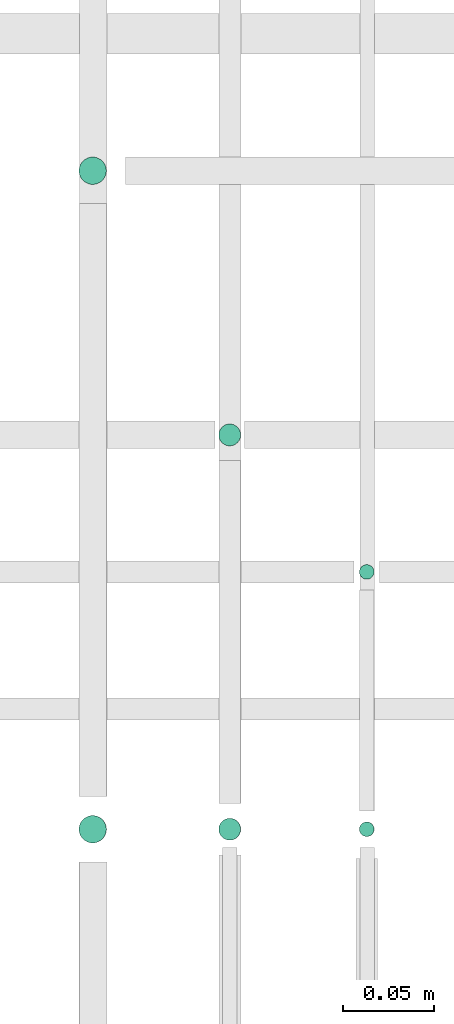
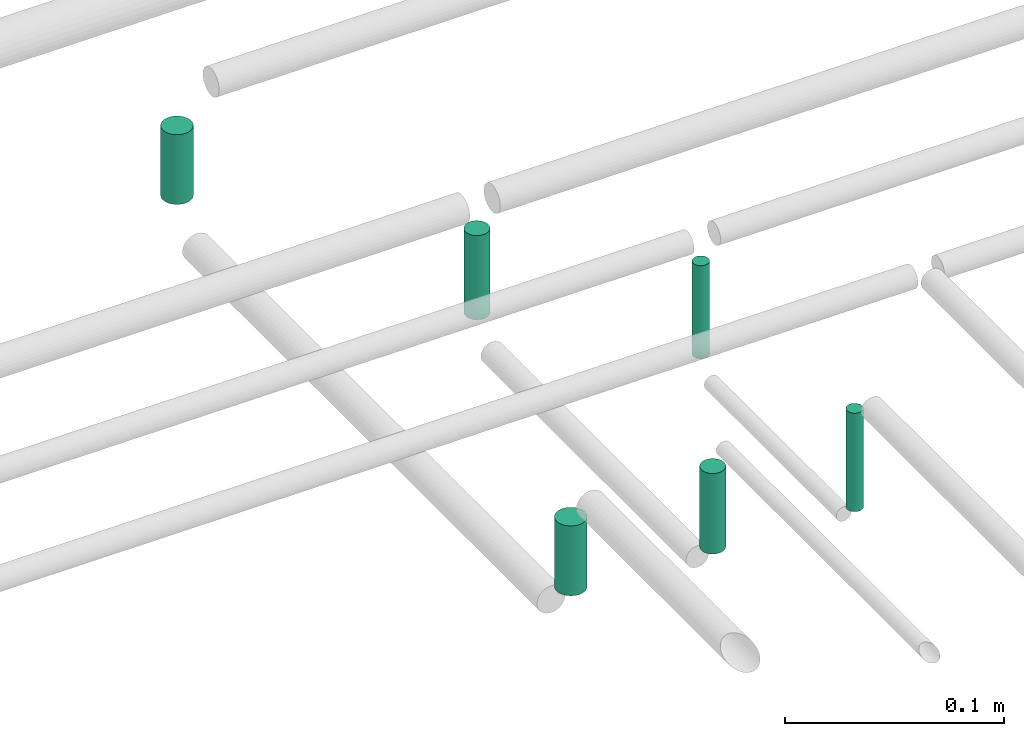
# One storey, part 253 of 331: 6 flow segments.
"""IFC2X3 building model written with IfcOpenShell, lengths in millimetres."""

import ifcopenshell
import ifcopenshell.guid

model = None  # the IFC model being written
_history = None  # IfcOwnerHistory: only IFC2X3 demands one
_inside = {}  # id of a spatial element -> (the spatial element, [elements in it])
_under = {}  # id of a project, library or spatial element -> (it, [spatial elements below it])
_declared = {}  # id of a project -> (the project, [libraries it declares])
_typed = {}  # id of a type object -> (the type object, [elements of that type])
_made_of = {}  # id of a material, layer set ... -> (it, [elements and type objects made of it])


def new_model(schema):
    """Start an empty IFC model of exactly this schema.

    Asked for "IFC4X3", IfcOpenShell would pick the latest addendum, in which some entities
    have other attributes; the version numbers below select the first issue.
    IFC2X3 requires an IfcOwnerHistory on every rooted entity: one is made here for all.
    """
    global model, _history
    if schema == "IFC4X3":
        model = ifcopenshell.file(schema_version=(4, 3, 0, 0))
    else:
        model = ifcopenshell.file(schema=schema)
    _inside.clear()
    _under.clear()
    _declared.clear()
    _typed.clear()
    _made_of.clear()
    _history = None
    if model.schema == "IFC2X3":
        org = make("IfcOrganization", Name="unknown")
        user = make(
            "IfcPersonAndOrganization",
            ThePerson=make("IfcPerson", FamilyName="unknown"),
            TheOrganization=org,
        )
        app = make(
            "IfcApplication",
            ApplicationDeveloper=org,
            Version="unknown",
            ApplicationFullName="unknown",
            ApplicationIdentifier="unknown",
        )
        _history = make(
            "IfcOwnerHistory",
            OwningUser=user,
            OwningApplication=app,
            ChangeAction="ADDED",
            CreationDate=0,
        )
    return model


def make(cls, **values):
    """One entity of the class cls with the attributes given. An attribute that is None is left unset."""
    return model.create_entity(
        cls, **{name: value for name, value in values.items() if value is not None}
    )


def entity(cls, *values):
    """Any entity or typed value of the class cls, its attributes in the order of the schema. None: left unset."""
    e = model.create_entity(cls)
    for i, value in enumerate(values):
        if value is not None:
            e[i] = value
    return e


def rooted(cls, **values):
    """An entity with a GlobalId (a new one), such as an element, a storey or a relation."""
    return make(cls, GlobalId=ifcopenshell.guid.new(), OwnerHistory=_history, **values)


def si_unit(unit_type, name, prefix=None):
    """IfcSIUnit, for example si_unit("LENGTHUNIT", "METRE", prefix="MILLI")."""
    return make("IfcSIUnit", UnitType=unit_type, Prefix=prefix, Name=name)


def converted_unit(unit_type, name, factor, base, dimensions=None, offset=None):
    """IfcConversionBasedUnit, such as the inch: factor (a typed value) times the base unit."""
    return make(
        "IfcConversionBasedUnit"
        if offset is None
        else "IfcConversionBasedUnitWithOffset",
        ConversionOffset=offset,
        Dimensions=None
        if dimensions is None
        else entity("IfcDimensionalExponents", *dimensions),
        UnitType=unit_type,
        Name=name,
        ConversionFactor=make(
            "IfcMeasureWithUnit", ValueComponent=factor, UnitComponent=base
        ),
    )


def derived_unit(unit_type, elements):
    """IfcDerivedUnit: a product of units, each with its exponent."""
    return make(
        "IfcDerivedUnit",
        Elements=[
            make("IfcDerivedUnitElement", Unit=unit, Exponent=power)
            for unit, power in elements
        ],
        UnitType=unit_type,
    )


def assignment(units):
    """IfcUnitAssignment: the units of a project."""
    return None if units is None else make("IfcUnitAssignment", Units=units)


def point(xyz):
    """IfcCartesianPoint."""
    return None if xyz is None else make("IfcCartesianPoint", Coordinates=xyz)


def direction(xyz):
    """IfcDirection."""
    return None if xyz is None else make("IfcDirection", DirectionRatios=xyz)


def frame(location, z_axis=None, x_axis=None):
    """IfcAxis2Placement3D, a coordinate frame: its origin and axes. An axis left out is left unset."""
    return make(
        "IfcAxis2Placement3D",
        Location=point(location),
        Axis=direction(z_axis),
        RefDirection=direction(x_axis),
    )


def frame_2d(location, x_axis=None):
    """IfcAxis2Placement2D, a coordinate frame in the plane: its origin and x axis."""
    return make(
        "IfcAxis2Placement2D", Location=point(location), RefDirection=direction(x_axis)
    )


def origin():
    """The frame at (0, 0, 0) with its axes left unset."""
    return frame((0.0, 0.0, 0.0))


def origin_2d_with_axis():
    """The frame at (0, 0) in the plane with the x axis (1, 0) written out."""
    return frame_2d((0.0, 0.0), x_axis=(1.0, 0.0))


def place(relative_to, where):
    """IfcLocalPlacement: puts the frame where relative to a parent placement (None: the world)."""
    return make(
        "IfcLocalPlacement", PlacementRelTo=relative_to, RelativePlacement=where
    )


def context(
    kind, dimensions, precision=None, world=None, true_north=None, identifier=None
):
    """IfcGeometricRepresentationContext, for example the 3D "Model" context."""
    return make(
        "IfcGeometricRepresentationContext",
        ContextIdentifier=identifier,
        ContextType=kind,
        CoordinateSpaceDimension=dimensions,
        Precision=precision,
        WorldCoordinateSystem=world,
        TrueNorth=true_north,
    )


def subcontext(parent, identifier, kind, view, scale=None):
    """IfcGeometricRepresentationSubContext, for example "Body" below "Model"."""
    return make(
        "IfcGeometricRepresentationSubContext",
        ContextIdentifier=identifier,
        ContextType=kind,
        ParentContext=parent,
        TargetScale=scale,
        TargetView=view,
    )


def project(units=None, contexts=None):
    """IfcProject with its units and contexts."""
    return rooted(
        "IfcProject",
        Name="project",
        RepresentationContexts=contexts,
        UnitsInContext=assignment(units),
    )


def spatial(cls, under=None, at=None, **own):
    """A site, building, storey or space (cls), placed at a placement, below another one or the project."""
    s = rooted(cls, ObjectPlacement=at, **own)
    if under is not None:
        _under.setdefault(under.id(), (under, []))[1].append(s)
    return s


def profile(cls, at=None, kind="AREA", **sizes):
    """A parametric profile (cls). Its sizes go by their IFC names, for example OverallWidth=200.0."""
    return make(cls, ProfileType=kind, Position=at, **sizes)


def circle(**sizes):
    """IfcCircleProfileDef."""
    return profile("IfcCircleProfileDef", **sizes)


def extrude(swept, where, along, depth):
    """IfcExtrudedAreaSolid: the profile swept, set in the frame where, extruded along a direction by depth."""
    return make(
        "IfcExtrudedAreaSolid",
        SweptArea=swept,
        Position=where,
        ExtrudedDirection=direction(along),
        Depth=depth,
    )


def shape(context_of_items, identifier, shape_type, items):
    """IfcShapeRepresentation: the items that make up one representation, for example the "Body"."""
    return make(
        "IfcShapeRepresentation",
        ContextOfItems=context_of_items,
        RepresentationIdentifier=identifier,
        RepresentationType=shape_type,
        Items=items,
    )


def made_of(thing, what):
    """Note that an element or type object is made of a material, layer set ...; save() writes the relation."""
    if what is not None:
        _made_of.setdefault(what.id(), (what, []))[1].append(thing)
    return thing


def type_object(cls, material=None, **own):
    """A type object (cls), such as IfcWallType, which elements share."""
    return made_of(rooted(cls, **own), material)


def element(
    cls,
    number,
    at=None,
    inside=None,
    cuts=None,
    type_object=None,
    material=None,
    context=None,
    identifier="Body",
    shape_type=None,
    held_by="IfcProductDefinitionShape",
    body=None,
    shapes=None,
    **own,
):
    """One element of the class cls, such as IfcWall. Its Tag is "e" and its number.

    at: its placement. inside: the storey or other place that contains it. cuts: it is an
    opening in that element (IfcRelVoidsElement). A single representation is given by context,
    identifier, shape_type and body (its items); several are given by shapes. held_by: the class
    of the entity that holds the representations. save() writes the other relations.
    """
    e = rooted(cls, Tag="e%d" % number, ObjectPlacement=at, **own)
    if body is not None:
        shapes = [shape(context, identifier, shape_type, body)]
    if shapes is not None:
        e.Representation = make(held_by, Representations=shapes)
    if inside is not None:
        _inside.setdefault(inside.id(), (inside, []))[1].append(e)
    if cuts is not None:
        rooted(
            "IfcRelVoidsElement", RelatingBuildingElement=cuts, RelatedOpeningElement=e
        )
    if type_object is not None:
        _typed.setdefault(type_object.id(), (type_object, []))[1].append(e)
    return made_of(e, material)


def aggregate(whole, parts):
    """IfcRelAggregates: a whole, such as a stair, and the parts it consists of."""
    return rooted("IfcRelAggregates", RelatingObject=whole, RelatedObjects=parts)


def save(model, path):
    """Write the relations noted so far, then the file.

    IfcRelAggregates (storeys below a building ...), IfcRelContainedInSpatialStructure (elements
    in a storey), IfcRelDefinesByType, IfcRelAssociatesMaterial and IfcRelDeclares: one each for
    every whole, place, type object, material and project.
    """
    for whole, parts in _under.values():
        aggregate(whole, parts)
    for where, things in _inside.values():
        rooted(
            "IfcRelContainedInSpatialStructure",
            RelatedElements=things,
            RelatingStructure=where,
        )
    for kind, things in _typed.values():
        rooted("IfcRelDefinesByType", RelatedObjects=things, RelatingType=kind)
    for what, things in _made_of.values():
        rooted("IfcRelAssociatesMaterial", RelatedObjects=things, RelatingMaterial=what)
    for by, libraries in _declared.values():
        rooted("IfcRelDeclares", RelatingContext=by, RelatedDefinitions=libraries)
    model.write(path)


model = new_model("IFC2X3")

# Units and contexts
model_context = context("Model", 3, precision=0.01, world=origin(), true_north=direction((6.12303176911189e-17, 1.0)))
body_context = subcontext(model_context, "Body", "Model", "MODEL_VIEW")
ifc_project = project(units=[si_unit("LENGTHUNIT", "METRE", prefix="MILLI"), si_unit("AREAUNIT", "SQUARE_METRE"), si_unit("VOLUMEUNIT", "CUBIC_METRE"), converted_unit("PLANEANGLEUNIT", "DEGREE", entity("IfcRatioMeasure", 0.0174532925199433), si_unit("PLANEANGLEUNIT", "RADIAN"), dimensions=[0, 0, 0, 0, 0, 0, 0]), si_unit("MASSUNIT", "GRAM", prefix="KILO"), derived_unit("MASSDENSITYUNIT", [(si_unit("MASSUNIT", "GRAM", prefix="KILO"), 1), (si_unit("LENGTHUNIT", "METRE"), -3)]), derived_unit("MOMENTOFINERTIAUNIT", [(si_unit("LENGTHUNIT", "METRE"), 4)]), si_unit("TIMEUNIT", "SECOND"), si_unit("FREQUENCYUNIT", "HERTZ"), si_unit("THERMODYNAMICTEMPERATUREUNIT", "DEGREE_CELSIUS"), derived_unit("THERMALTRANSMITTANCEUNIT", [(si_unit("MASSUNIT", "GRAM", prefix="KILO"), 1), (si_unit("THERMODYNAMICTEMPERATUREUNIT", "KELVIN"), -1), (si_unit("TIMEUNIT", "SECOND"), -3)]), derived_unit("VOLUMETRICFLOWRATEUNIT", [(si_unit("LENGTHUNIT", "METRE"), 3), (si_unit("TIMEUNIT", "SECOND"), -1)]), derived_unit("MASSFLOWRATEUNIT", [(si_unit("MASSUNIT", "GRAM", prefix="KILO"), 1), (si_unit("TIMEUNIT", "SECOND"), -1)]), derived_unit("ROTATIONALFREQUENCYUNIT", [(si_unit("TIMEUNIT", "SECOND"), -1)]), si_unit("ELECTRICCURRENTUNIT", "AMPERE"), si_unit("ELECTRICVOLTAGEUNIT", "VOLT"), si_unit("POWERUNIT", "WATT"), si_unit("FORCEUNIT", "NEWTON", prefix="KILO"), si_unit("ILLUMINANCEUNIT", "LUX"), si_unit("LUMINOUSFLUXUNIT", "LUMEN"), si_unit("LUMINOUSINTENSITYUNIT", "CANDELA"), derived_unit("USERDEFINED", [(si_unit("MASSUNIT", "GRAM", prefix="KILO"), -1), (si_unit("LENGTHUNIT", "METRE"), -2), (si_unit("TIMEUNIT", "SECOND"), 3), (si_unit("LUMINOUSFLUXUNIT", "LUMEN"), 1)]), derived_unit("LINEARVELOCITYUNIT", [(si_unit("LENGTHUNIT", "METRE"), 1), (si_unit("TIMEUNIT", "SECOND"), -1)]), si_unit("PRESSUREUNIT", "PASCAL"), derived_unit("USERDEFINED", [(si_unit("LENGTHUNIT", "METRE"), -2), (si_unit("MASSUNIT", "GRAM", prefix="KILO"), 1), (si_unit("TIMEUNIT", "SECOND"), -2)]), derived_unit("LINEARFORCEUNIT", [(si_unit("MASSUNIT", "GRAM", prefix="KILO"), 1), (si_unit("LENGTHUNIT", "METRE"), 1), (si_unit("TIMEUNIT", "SECOND"), -2), (si_unit("LENGTHUNIT", "METRE"), -1)]), derived_unit("PLANARFORCEUNIT", [(si_unit("MASSUNIT", "GRAM", prefix="KILO"), 1), (si_unit("LENGTHUNIT", "METRE"), 1), (si_unit("TIMEUNIT", "SECOND"), -2), (si_unit("LENGTHUNIT", "METRE"), -2)])], contexts=[model_context])

# Site, building, storey
site_placement = place(None, frame((0.0, -0.00077364408347762, 0.0)))
site = spatial("IfcSite", under=ifc_project, at=site_placement, CompositionType="ELEMENT")
building_placement = place(site_placement, origin())
building = spatial("IfcBuilding", under=site, at=building_placement, CompositionType="ELEMENT")
storey_placement = place(building_placement, origin())
storey = spatial("IfcBuildingStorey", under=building, at=storey_placement, CompositionType="ELEMENT", Elevation=0.0)

# Flow segments
pipe_segment_type = type_object("IfcPipeSegmentType", PredefinedType="NOTDEFINED")
flow_segment_1_placement = place(storey_placement, frame((20688.5132627125, 8082.55353441897, 14489.0)))
element("IfcFlowSegment", 1, at=flow_segment_1_placement, inside=storey, type_object=pipe_segment_type, context=body_context, shape_type="SweptSolid", body=[
    extrude(circle(Radius=6.0, at=origin_2d_with_axis()), frame((7.59527223591454, 7.59527223591562, 0.0), z_axis=(0.0, 0.0, 1.0), x_axis=(-1.0, 0.0, 0.0)), (0.0, 0.0, 1.0), 44.9999998911075),
])
flow_segment_2_placement = place(storey_placement, frame((20765.5132627125, 8084.55353441895, 14485.0)))
element("IfcFlowSegment", 2, at=flow_segment_2_placement, inside=storey, type_object=pipe_segment_type, context=body_context, shape_type="SweptSolid", body=[
    extrude(circle(Radius=4.0, at=origin_2d_with_axis()), frame((5.59527223591499, 5.59527223591607, 0.0), z_axis=(0.0, 0.0, 1.0), x_axis=(-1.0, 0.0, 0.0)), (0.0, 0.0, 1.0), 54.9999998911052),
])
flow_segment_3_placement = place(storey_placement, frame((20612.0132627125, 8441.52529159143, 14493.0)))
element("IfcFlowSegment", 3, at=flow_segment_3_placement, inside=storey, type_object=pipe_segment_type, context=body_context, shape_type="SweptSolid", body=[
    extrude(circle(Radius=7.5, at=origin_2d_with_axis()), frame((9.09527223591419, 9.09527223591636, 0.0)), (0.0, 0.0, 1.0), 38.9999998910634),
])
flow_segment_4_placement = place(storey_placement, frame((20612.0132627125, 8081.05353441896, 14493.0)))
element("IfcFlowSegment", 4, at=flow_segment_4_placement, inside=storey, type_object=pipe_segment_type, context=body_context, shape_type="SweptSolid", body=[
    extrude(circle(Radius=7.5, at=origin_2d_with_axis()), frame((9.09527223591419, 9.09527223591636, 0.0), z_axis=(0.0, 0.0, 1.0), x_axis=(-1.0, 0.0, 0.0)), (0.0, 0.0, 1.0), 38.9999998911045),
])
flow_segment_5_placement = place(storey_placement, frame((20765.5132627125, 8225.41467161343, 14485.0)))
element("IfcFlowSegment", 5, at=flow_segment_5_placement, inside=storey, type_object=pipe_segment_type, context=body_context, shape_type="SweptSolid", body=[
    extrude(circle(Radius=4.0, at=origin_2d_with_axis()), frame((5.59527223591499, 5.59527223591607, 2.58062397051617e-07)), (0.0, 0.0, 1.0), 51.9999160184814),
])
flow_segment_6_placement = place(storey_placement, frame((20688.5132590175, 8298.41467161343, 14489.0)))
element("IfcFlowSegment", 6, at=flow_segment_6_placement, inside=storey, type_object=pipe_segment_type, context=body_context, shape_type="SweptSolid", body=[
    extrude(circle(Radius=6.0, at=frame_2d((0.0, -1.08286712929839e-12), x_axis=(1.0, 0.0))), frame((7.5952759309214, 7.5952722359167, 4.71718578864966e-07)), (0.0, 0.0, 1.0), 46.9983741000654),
])

save(model, "model.ifc")
